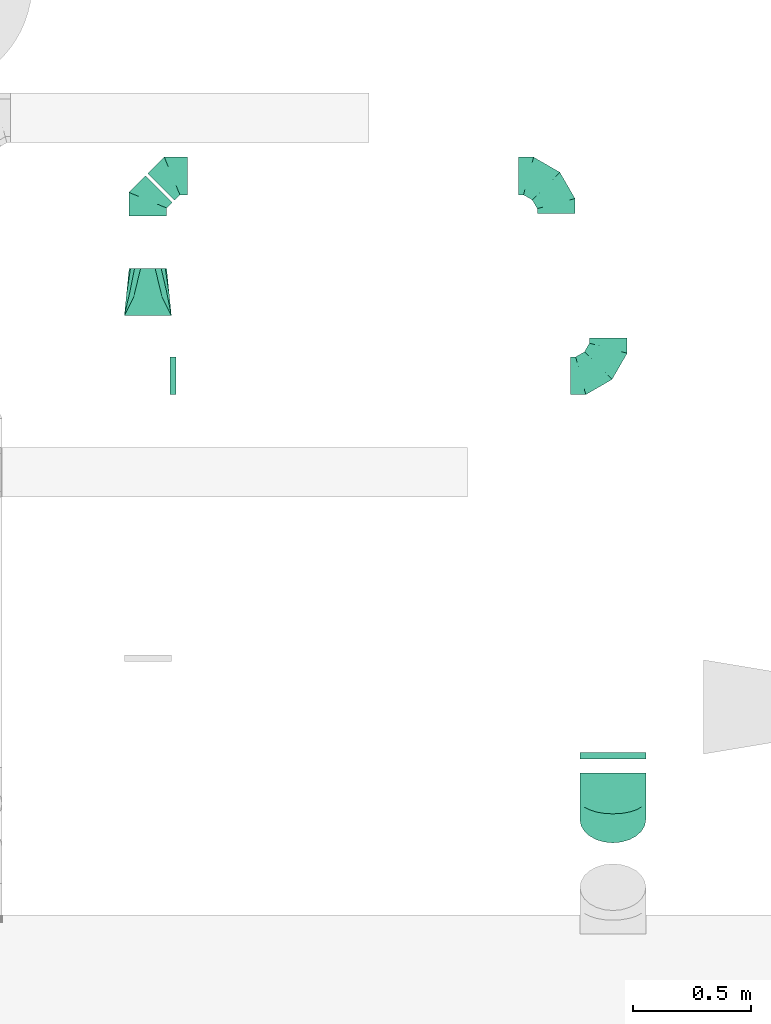
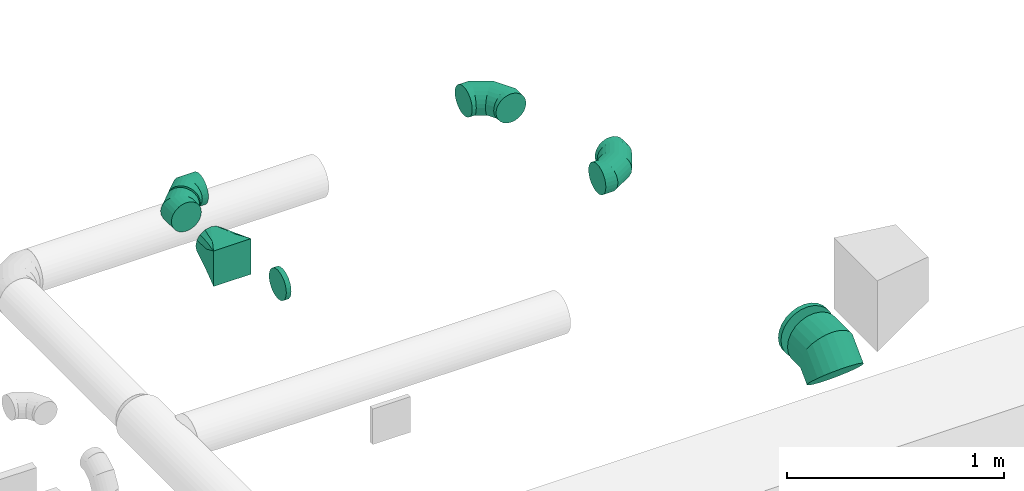
# One storey, part 44 of 62: 8 flow fittings.
"""IFC2X3 building model written with IfcOpenShell, lengths in millimetres."""

from ifc_helpers import new_model, entity, si_unit, converted_unit, derived_unit, direction, frame, origin, place, context, subcontext, project, spatial, faceted_brep, source, transform, mapped, material, type_object, type_shapes, element, save


model = new_model("IFC2X3")

# Units and contexts
model_context = context("Model", 3, precision=0.01, world=origin(), true_north=direction((6.12303176911189e-17, 1.0)))
body_context = subcontext(model_context, "Body", "Model", "MODEL_VIEW")
ifc_project = project(units=[si_unit("LENGTHUNIT", "METRE", prefix="MILLI"), si_unit("AREAUNIT", "SQUARE_METRE"), si_unit("VOLUMEUNIT", "CUBIC_METRE"), converted_unit("PLANEANGLEUNIT", "DEGREE", entity("IfcRatioMeasure", 0.0174532925199433), si_unit("PLANEANGLEUNIT", "RADIAN"), dimensions=[0, 0, 0, 0, 0, 0, 0]), si_unit("MASSUNIT", "GRAM", prefix="KILO"), derived_unit("MASSDENSITYUNIT", [(si_unit("MASSUNIT", "GRAM", prefix="KILO"), 1), (si_unit("LENGTHUNIT", "METRE"), -3)]), derived_unit("MOMENTOFINERTIAUNIT", [(si_unit("LENGTHUNIT", "METRE"), 4)]), si_unit("TIMEUNIT", "SECOND"), si_unit("FREQUENCYUNIT", "HERTZ"), si_unit("THERMODYNAMICTEMPERATUREUNIT", "DEGREE_CELSIUS"), derived_unit("THERMALTRANSMITTANCEUNIT", [(si_unit("MASSUNIT", "GRAM", prefix="KILO"), 1), (si_unit("THERMODYNAMICTEMPERATUREUNIT", "KELVIN"), -1), (si_unit("TIMEUNIT", "SECOND"), -3)]), derived_unit("VOLUMETRICFLOWRATEUNIT", [(si_unit("LENGTHUNIT", "METRE"), 3), (si_unit("TIMEUNIT", "SECOND"), -1)]), derived_unit("MASSFLOWRATEUNIT", [(si_unit("MASSUNIT", "GRAM", prefix="KILO"), 1), (si_unit("TIMEUNIT", "SECOND"), -1)]), derived_unit("ROTATIONALFREQUENCYUNIT", [(si_unit("TIMEUNIT", "SECOND"), -1)]), si_unit("ELECTRICCURRENTUNIT", "AMPERE"), si_unit("ELECTRICVOLTAGEUNIT", "VOLT"), si_unit("POWERUNIT", "WATT"), si_unit("FORCEUNIT", "NEWTON", prefix="KILO"), si_unit("ILLUMINANCEUNIT", "LUX"), si_unit("LUMINOUSFLUXUNIT", "LUMEN"), si_unit("LUMINOUSINTENSITYUNIT", "CANDELA"), derived_unit("USERDEFINED", [(si_unit("MASSUNIT", "GRAM", prefix="KILO"), -1), (si_unit("LENGTHUNIT", "METRE"), -2), (si_unit("TIMEUNIT", "SECOND"), 3), (si_unit("LUMINOUSFLUXUNIT", "LUMEN"), 1)]), derived_unit("LINEARVELOCITYUNIT", [(si_unit("LENGTHUNIT", "METRE"), 1), (si_unit("TIMEUNIT", "SECOND"), -1)]), si_unit("PRESSUREUNIT", "PASCAL"), derived_unit("USERDEFINED", [(si_unit("LENGTHUNIT", "METRE"), -2), (si_unit("MASSUNIT", "GRAM", prefix="KILO"), 1), (si_unit("TIMEUNIT", "SECOND"), -2)]), derived_unit("LINEARFORCEUNIT", [(si_unit("MASSUNIT", "GRAM", prefix="KILO"), 1), (si_unit("LENGTHUNIT", "METRE"), 1), (si_unit("TIMEUNIT", "SECOND"), -2), (si_unit("LENGTHUNIT", "METRE"), -1)]), derived_unit("PLANARFORCEUNIT", [(si_unit("MASSUNIT", "GRAM", prefix="KILO"), 1), (si_unit("LENGTHUNIT", "METRE"), 1), (si_unit("TIMEUNIT", "SECOND"), -2), (si_unit("LENGTHUNIT", "METRE"), -2)])], contexts=[model_context])

# Site, building, storey
site_placement = place(None, origin())
site = spatial("IfcSite", under=ifc_project, at=site_placement, CompositionType="ELEMENT")
building_placement = place(site_placement, origin())
building = spatial("IfcBuilding", under=site, at=building_placement, CompositionType="ELEMENT")
storey_placement = place(building_placement, frame((0.0, 0.0, 24000.0)))
storey = spatial("IfcBuildingStorey", under=building, at=storey_placement, CompositionType="ELEMENT", Elevation=24000.0)

# Flow fittings
ifc_material = material()
duct_fitting_type_1 = type_object("IfcDuctFittingType", PredefinedType="NOTDEFINED", material=ifc_material)
shared_shape_1 = source(origin(), body_context, "Body", "Brep", [
    faceted_brep([(-160.0, 0.0, -80.0), (-160.0, -20.71, -77.27), (-160.0, -40.0, -69.28), (-160.0, -56.57, -56.57), (-160.0, -69.28, -40.0), (-160.0, -77.27, -20.71), (-160.0, -80.0, 0.0), (-160.0, -77.27, 20.71), (-160.0, -69.28, 40.0), (-160.0, -56.57, 56.57), (-160.0, -40.0, 69.28), (-160.0, -20.71, 77.27), (-160.0, 0.0, 80.0), (-160.0, 20.71, 77.27), (-160.0, 40.0, 69.28), (-160.0, 56.57, 56.57), (-160.0, 69.28, 40.0), (-160.0, 77.27, 20.71), (-160.0, 80.0, 0.0), (-160.0, 77.27, -20.71), (-160.0, 69.28, -40.0), (-160.0, 56.57, -56.57), (-160.0, 40.0, -69.28), (-160.0, 20.71, -77.27), (-122.68, 20.71, 77.27), (-127.85, 40.0, 69.28), (-117.13, 0.0, 80.0), (-132.29, 56.57, 56.57), (-137.83, 77.27, 20.71), (-138.56, 80.0, 0.0), (-135.69, 69.28, 40.0), (-135.69, 69.28, -40.0), (-132.29, 56.57, -56.57), (-137.83, 77.27, -20.71), (-122.68, 20.71, -77.27), (-117.13, 0.0, -80.0), (-127.85, 40.0, -69.28), (-111.58, -20.71, -77.27), (-106.41, -40.0, -69.28), (-101.97, -56.57, -56.57), (-98.56, -69.28, -40.0), (-96.42, -77.27, -20.71), (-95.69, -80.0, 0.0), (-96.42, -77.27, 20.71), (-98.56, -69.28, 40.0), (-101.97, -56.57, 56.57), (-106.41, -40.0, 69.28), (-111.58, -20.71, 77.27), (-58.03, 58.03, 77.27), (-72.15, 72.15, 69.28), (-42.87, 42.87, 80.0), (-84.28, 84.28, 56.57), (-93.59, 93.59, 40.0), (-99.44, 99.44, 20.71), (-101.44, 101.44, 0.0), (-99.44, 99.44, -20.71), (-93.59, 93.59, -40.0), (-84.28, 84.28, -56.57), (-58.03, 58.03, -77.27), (-42.87, 42.87, -80.0), (-72.15, 72.15, -69.28), (-27.71, 27.71, -77.27), (-13.59, 13.59, -69.28), (-1.46, 1.46, -56.57), (7.85, -7.85, -40.0), (13.7, -13.7, -20.71), (15.69, -15.69, 0.0), (13.7, -13.7, 20.71), (7.85, -7.85, 40.0), (-1.46, 1.46, 56.57), (-13.59, 13.59, 69.28), (-27.71, 27.71, 77.27), (-20.71, 122.68, 77.27), (-40.0, 127.85, 69.28), (0.0, 117.13, 80.0), (-56.57, 132.29, 56.57), (-69.28, 135.69, 40.0), (-77.27, 137.83, 20.71), (-80.0, 138.56, 0.0), (-77.27, 137.83, -20.71), (-69.28, 135.69, -40.0), (-56.57, 132.29, -56.57), (-20.71, 122.68, -77.27), (0.0, 117.13, -80.0), (-40.0, 127.85, -69.28), (20.71, 111.58, -77.27), (40.0, 106.41, -69.28), (56.57, 101.97, -56.57), (69.28, 98.56, -40.0), (77.27, 96.42, -20.71), (80.0, 95.69, 0.0), (77.27, 96.42, 20.71), (69.28, 98.56, 40.0), (56.57, 101.97, 56.57), (40.0, 106.41, 69.28), (20.71, 111.58, 77.27), (-20.71, 160.0, -77.27), (-40.0, 160.0, -69.28), (-56.57, 160.0, -56.57), (-69.28, 160.0, -40.0), (-77.27, 160.0, -20.71), (-80.0, 160.0, 0.0), (-77.27, 160.0, 20.71), (-69.28, 160.0, 40.0), (-56.57, 160.0, 56.57), (-40.0, 160.0, 69.28), (-20.71, 160.0, 77.27), (0.0, 160.0, 80.0), (20.71, 160.0, 77.27), (40.0, 160.0, 69.28), (56.57, 160.0, 56.57), (69.28, 160.0, 40.0), (77.27, 160.0, 20.71), (80.0, 160.0, 0.0), (77.27, 160.0, -20.71), (69.28, 160.0, -40.0), (56.57, 160.0, -56.57), (40.0, 160.0, -69.28), (20.71, 160.0, -77.27), (0.0, 160.0, -80.0)], [[[0, 1, 2, 3, 4, 5, 6, 7, 8, 9, 10, 11, 12, 13, 14, 15, 16, 17, 18, 19, 20, 21, 22, 23]], [[24, 25, 14, 13]], [[26, 24, 13, 12]], [[14, 25, 27, 15]], [[28, 29, 18, 17]], [[30, 28, 17, 16]], [[15, 27, 30, 16]], [[20, 31, 32, 21]], [[33, 31, 20, 19]], [[18, 29, 33, 19]], [[34, 35, 0, 23]], [[36, 34, 23, 22]], [[32, 36, 22, 21]], [[1, 0, 35, 37]], [[2, 1, 37, 38]], [[3, 2, 38, 39]], [[5, 4, 40, 41]], [[6, 5, 41, 42]], [[39, 40, 4, 3]], [[6, 42, 43, 7]], [[7, 43, 44, 8]], [[8, 44, 45, 9]], [[9, 45, 46, 10]], [[10, 46, 47, 11]], [[26, 12, 11, 47]], [[48, 49, 25, 24]], [[50, 48, 24, 26]], [[27, 25, 49, 51]], [[52, 53, 28, 30]], [[51, 52, 30, 27]], [[29, 28, 53, 54]], [[55, 56, 31, 33]], [[54, 55, 33, 29]], [[32, 31, 56, 57]], [[58, 59, 35, 34]], [[60, 58, 34, 36]], [[57, 60, 36, 32]], [[37, 35, 59, 61]], [[38, 37, 61, 62]], [[39, 38, 62, 63]], [[41, 40, 64, 65]], [[42, 41, 65, 66]], [[63, 64, 40, 39]], [[43, 42, 66, 67]], [[44, 43, 67, 68]], [[68, 69, 45, 44]], [[46, 45, 69, 70]], [[47, 46, 70, 71]], [[26, 47, 71, 50]], [[72, 73, 49, 48]], [[74, 72, 48, 50]], [[51, 49, 73, 75]], [[76, 77, 53, 52]], [[75, 76, 52, 51]], [[54, 53, 77, 78]], [[79, 80, 56, 55]], [[78, 79, 55, 54]], [[57, 56, 80, 81]], [[82, 83, 59, 58]], [[84, 82, 58, 60]], [[81, 84, 60, 57]], [[61, 59, 83, 85]], [[62, 61, 85, 86]], [[63, 62, 86, 87]], [[65, 64, 88, 89]], [[66, 65, 89, 90]], [[87, 88, 64, 63]], [[67, 66, 90, 91]], [[68, 67, 91, 92]], [[92, 93, 69, 68]], [[70, 69, 93, 94]], [[71, 70, 94, 95]], [[50, 71, 95, 74]], [[96, 97, 98, 99, 100, 101, 102, 103, 104, 105, 106, 107, 108, 109, 110, 111, 112, 113, 114, 115, 116, 117, 118, 119]], [[72, 74, 107, 106]], [[73, 72, 106, 105]], [[75, 73, 105, 104]], [[77, 76, 103, 102]], [[78, 77, 102, 101]], [[75, 104, 103, 76]], [[78, 101, 100, 79]], [[79, 100, 99, 80]], [[80, 99, 98, 81]], [[84, 97, 96, 82]], [[82, 96, 119, 83]], [[84, 81, 98, 97]], [[118, 117, 86, 85]], [[119, 118, 85, 83]], [[116, 87, 86, 117]], [[88, 115, 114, 89]], [[89, 114, 113, 90]], [[115, 88, 87, 116]], [[112, 111, 92, 91]], [[113, 112, 91, 90]], [[111, 110, 93, 92]], [[95, 94, 109, 108]], [[74, 95, 108, 107]], [[110, 109, 94, 93]]]),
])
type_shapes(duct_fitting_type_1, [shared_shape_1])
flow_fitting_1_placement = place(storey_placement, frame((56810.22, 12336.18, 3550.0), z_axis=(0.0, 0.0, 1.0), x_axis=(0.0, 1.0, 0.0)))
element("IfcFlowFitting", 1, at=flow_fitting_1_placement, inside=storey, type_object=duct_fitting_type_1, material=ifc_material, context=body_context, shape_type="MappedRepresentation", body=[
    mapped(shared_shape_1, transform((0.0, 0.0, 0.0), scale=1.0)),
])
flow_fitting_2_placement = place(storey_placement, frame((57031.65, 11488.11, 3550.0)))
element("IfcFlowFitting", 2, at=flow_fitting_2_placement, inside=storey, type_object=duct_fitting_type_1, material=ifc_material, context=body_context, shape_type="MappedRepresentation", body=[
    mapped(shared_shape_1, transform((0.0, 0.0, 0.0), scale=1.0)),
])
duct_fitting_type_2 = type_object("IfcDuctFittingType", PredefinedType="NOTDEFINED", material=ifc_material)
shared_shape_2 = source(origin(), body_context, "Body", "Brep", [
    faceted_brep([(20.0, 0.0, -80.0), (20.0, 20.71, -77.27), (20.0, 40.0, -69.28), (20.0, 56.57, -56.57), (20.0, 69.28, -40.0), (20.0, 77.27, -20.71), (20.0, 80.0, 0.0), (20.0, 77.27, 20.71), (20.0, 69.28, 40.0), (20.0, 56.57, 56.57), (20.0, 40.0, 69.28), (20.0, 20.71, 77.27), (20.0, 0.0, 80.0), (20.0, -20.71, 77.27), (20.0, -40.0, 69.28), (20.0, -56.57, 56.57), (20.0, -69.28, 40.0), (20.0, -77.27, 20.71), (20.0, -80.0, 0.0), (20.0, -77.27, -20.71), (20.0, -69.28, -40.0), (20.0, -56.57, -56.57), (20.0, -40.0, -69.28), (20.0, -20.71, -77.27), (0.0, 0.0, 80.0), (-6.1, 0.0, 80.0), (-6.1, -20.71, 77.27), (0.0, -20.71, 77.27), (-6.1, -40.0, 69.28), (0.0, -40.0, 69.28), (0.0, -56.57, 56.57), (-6.1, -56.57, 56.57), (0.0, -69.28, 40.0), (-6.1, -69.28, 40.0), (-6.1, -77.27, 20.71), (0.0, -77.27, 20.71), (-6.1, -80.0, 0.0), (0.0, -80.0, 0.0), (-6.1, -77.27, -20.71), (0.0, -77.27, -20.71), (-6.1, -69.28, -40.0), (0.0, -69.28, -40.0), (0.0, -56.57, -56.57), (-6.1, -56.57, -56.57), (0.0, -40.0, -69.28), (-6.1, -40.0, -69.28), (-6.1, -20.71, -77.27), (0.0, -20.71, -77.27), (-6.1, 0.0, -80.0), (0.0, 0.0, -80.0), (-6.1, 20.71, -77.27), (0.0, 20.71, -77.27), (-6.1, 40.0, -69.28), (0.0, 40.0, -69.28), (0.0, 56.57, -56.57), (-6.1, 56.57, -56.57), (0.0, 69.28, -40.0), (-6.1, 69.28, -40.0), (-6.1, 77.27, -20.71), (0.0, 77.27, -20.71), (-6.1, 80.0, 0.0), (0.0, 80.0, 0.0), (-6.1, 77.27, 20.71), (0.0, 77.27, 20.71), (-6.1, 69.28, 40.0), (0.0, 69.28, 40.0), (0.0, 56.57, 56.57), (-6.1, 56.57, 56.57), (0.0, 40.0, 69.28), (-6.1, 40.0, 69.28), (-6.1, 20.71, 77.27), (0.0, 20.71, 77.27)], [[[0, 1, 2, 3, 4, 5, 6, 7, 8, 9, 10, 11, 12, 13, 14, 15, 16, 17, 18, 19, 20, 21, 22, 23]], [[13, 12, 24, 25, 26, 27]], [[14, 13, 27, 26, 28, 29]], [[30, 15, 14, 29, 28, 31]], [[17, 16, 32, 33, 34, 35]], [[18, 17, 35, 34, 36, 37]], [[32, 16, 15, 30, 31, 33]], [[19, 18, 37, 36, 38, 39]], [[20, 19, 39, 38, 40, 41]], [[42, 21, 20, 41, 40, 43]], [[23, 22, 44, 45, 46, 47]], [[0, 23, 47, 46, 48, 49]], [[44, 22, 21, 42, 43, 45]], [[1, 0, 49, 48, 50, 51]], [[2, 1, 51, 50, 52, 53]], [[54, 3, 2, 53, 52, 55]], [[5, 4, 56, 57, 58, 59]], [[6, 5, 59, 58, 60, 61]], [[56, 4, 3, 54, 55, 57]], [[7, 6, 61, 60, 62, 63]], [[8, 7, 63, 62, 64, 65]], [[66, 9, 8, 65, 64, 67]], [[11, 10, 68, 69, 70, 71]], [[12, 11, 71, 70, 25, 24]], [[68, 10, 9, 66, 67, 69]], [[46, 45, 43, 40, 38, 36, 34, 33, 31, 28, 26, 25, 70, 69, 67, 64, 62, 60, 58, 57, 55, 52, 50, 48]]]),
])
type_shapes(duct_fitting_type_2, [shared_shape_2])
flow_fitting_3_placement = place(storey_placement, frame((55177.37, 11488.11, 3550.0), z_axis=(0.0, 0.0, -1.0), x_axis=(1.0, 0.0, 0.0)))
element("IfcFlowFitting", 3, at=flow_fitting_3_placement, inside=storey, type_object=duct_fitting_type_2, material=ifc_material, context=body_context, shape_type="MappedRepresentation", body=[
    mapped(shared_shape_2, transform((0.0, 0.0, 0.0), scale=1.0)),
])
duct_fitting_type_3 = type_object("IfcDuctFittingType", PredefinedType="NOTDEFINED", material=ifc_material)
shared_shape_3 = source(origin(), body_context, "Body", "Brep", [
    faceted_brep([(-66.27, 0.0, -80.0), (-66.27, -20.71, -77.27), (-66.27, -40.0, -69.28), (-66.27, -56.57, -56.57), (-66.27, -69.28, -40.0), (-66.27, -77.27, -20.71), (-66.27, -80.0, 0.0), (-66.27, -77.27, 20.71), (-66.27, -69.28, 40.0), (-66.27, -56.57, 56.57), (-66.27, -40.0, 69.28), (-66.27, -20.71, 77.27), (-66.27, 0.0, 80.0), (-66.27, 20.71, 77.27), (-66.27, 40.0, 69.28), (-66.27, 56.57, 56.57), (-66.27, 69.28, 40.0), (-66.27, 77.27, 20.71), (-66.27, 80.0, 0.0), (-66.27, 77.27, -20.71), (-66.27, 69.28, -40.0), (-66.27, 56.57, -56.57), (-66.27, 40.0, -69.28), (-66.27, 20.71, -77.27), (-8.58, 20.71, 77.27), (-16.57, 40.0, 69.28), (0.0, 0.0, 80.0), (-23.43, 56.57, 56.57), (-28.7, 69.28, 40.0), (-32.01, 77.27, 20.71), (-33.14, 80.0, 0.0), (-32.01, 77.27, -20.71), (-28.7, 69.28, -40.0), (-23.43, 56.57, -56.57), (-8.58, 20.71, -77.27), (0.0, 0.0, -80.0), (-16.57, 40.0, -69.28), (8.58, -20.71, -77.27), (16.57, -40.0, -69.28), (23.43, -56.57, -56.57), (28.7, -69.28, -40.0), (32.01, -77.27, -20.71), (33.14, -80.0, 0.0), (32.01, -77.27, 20.71), (28.7, -69.28, 40.0), (23.43, -56.57, 56.57), (16.57, -40.0, 69.28), (8.58, -20.71, 77.27), (46.86, 46.86, 80.0), (32.22, 61.5, 77.27), (18.58, 75.15, 69.28), (6.86, 86.86, 56.57), (-2.13, 95.85, 40.0), (-7.78, 101.5, 20.71), (-9.71, 103.43, 0.0), (-7.78, 101.5, -20.71), (-2.13, 95.85, -40.0), (6.86, 86.86, -56.57), (18.58, 75.15, -69.28), (32.22, 61.5, -77.27), (46.86, 46.86, -80.0), (61.5, 32.22, -77.27), (75.15, 18.58, -69.28), (86.86, 6.86, -56.57), (95.85, -2.13, -40.0), (101.5, -7.78, -20.71), (103.43, -9.71, 0.0), (101.5, -7.78, 20.71), (95.85, -2.13, 40.0), (86.86, 6.86, 56.57), (75.15, 18.58, 69.28), (61.5, 32.22, 77.27)], [[[0, 1, 2, 3, 4, 5, 6, 7, 8, 9, 10, 11, 12, 13, 14, 15, 16, 17, 18, 19, 20, 21, 22, 23]], [[24, 25, 14, 13]], [[26, 24, 13, 12]], [[14, 25, 27, 15]], [[28, 29, 17, 16]], [[28, 16, 15, 27]], [[30, 18, 17, 29]], [[31, 32, 20, 19]], [[30, 31, 19, 18]], [[32, 33, 21, 20]], [[34, 35, 0, 23]], [[36, 34, 23, 22]], [[33, 36, 22, 21]], [[1, 0, 35, 37]], [[2, 1, 37, 38]], [[38, 39, 3, 2]], [[5, 4, 40, 41]], [[6, 5, 41, 42]], [[39, 40, 4, 3]], [[6, 42, 43, 7]], [[7, 43, 44, 8]], [[8, 44, 45, 9]], [[9, 45, 46, 10]], [[10, 46, 47, 11]], [[26, 12, 11, 47]], [[24, 26, 48, 49]], [[25, 24, 49, 50]], [[27, 25, 50, 51]], [[29, 28, 52, 53]], [[30, 29, 53, 54]], [[51, 52, 28, 27]], [[30, 54, 55, 31]], [[31, 55, 56, 32]], [[57, 33, 32, 56]], [[36, 58, 59, 34]], [[34, 59, 60, 35]], [[58, 36, 33, 57]], [[35, 60, 61, 37]], [[37, 61, 62, 38]], [[63, 39, 38, 62]], [[40, 64, 65, 41]], [[41, 65, 66, 42]], [[64, 40, 39, 63]], [[43, 42, 66, 67]], [[44, 43, 67, 68]], [[68, 69, 45, 44]], [[47, 46, 70, 71]], [[26, 47, 71, 48]], [[69, 70, 46, 45]], [[59, 58, 57, 56, 55, 54, 53, 52, 51, 50, 49, 48, 71, 70, 69, 68, 67, 66, 65, 64, 63, 62, 61, 60]]]),
])
type_shapes(duct_fitting_type_3, [shared_shape_3])
for number, where, z_axis, x_axis in (
    (4, (55077.37, 12233.33, 3550.0), (0.0, 0.0, 1.0), (-0.70710678118655, -0.707106781186545, 0.0)),
    (5, (55180.22, 12336.18, 3550.0), (0.0, 0.0, 1.0), (-1.0, 0.0, 0.0)),
):
    element("IfcFlowFitting", number, at=place(storey_placement, frame(where, z_axis=z_axis, x_axis=x_axis)), inside=storey, type_object=duct_fitting_type_3, material=ifc_material, context=body_context, shape_type="MappedRepresentation", body=[
        mapped(shared_shape_3, transform((0.0, 0.0, 0.0), scale=1.0)),
    ])
duct_fitting_type_4 = type_object("IfcDuctFittingType", PredefinedType="NOTDEFINED", material=ifc_material)
shared_shape_4 = source(origin(), body_context, "Body", "Brep", [
    faceted_brep([(200.0, 30.61, 73.91), (200.0, 22.87, 75.45), (200.0, 15.12, 76.99), (200.0, 11.34, 77.74), (200.0, 7.56, 78.5), (200.0, 0.0, 80.0), (200.0, -7.56, 78.5), (200.0, -15.12, 76.99), (200.0, -18.99, 76.22), (200.0, -22.87, 75.45), (200.0, -30.61, 73.91), (200.0, -37.1, 69.57), (200.0, -43.59, 65.24), (200.0, -50.08, 60.9), (200.0, -56.57, 56.57), (200.0, -60.9, 50.08), (200.0, -65.24, 43.59), (200.0, -69.57, 37.1), (200.0, -73.91, 30.61), (200.0, -75.45, 22.87), (200.0, -76.99, 15.12), (200.0, -77.74, 11.34), (200.0, -78.5, 7.56), (200.0, -80.0, 0.0), (200.0, -78.5, -7.56), (200.0, -76.99, -15.12), (200.0, -76.22, -18.99), (200.0, -75.45, -22.87), (200.0, -73.91, -30.61), (200.0, -69.57, -37.1), (200.0, -65.24, -43.59), (200.0, -60.9, -50.08), (200.0, -56.57, -56.57), (200.0, -50.08, -60.9), (200.0, -43.59, -65.24), (200.0, -37.1, -69.57), (200.0, -30.61, -73.91), (200.0, -22.87, -75.45), (200.0, -15.12, -76.99), (200.0, -11.34, -77.74), (200.0, -7.56, -78.5), (200.0, 0.0, -80.0), (200.0, 7.56, -78.5), (200.0, 15.12, -76.99), (200.0, 18.99, -76.22), (200.0, 22.87, -75.45), (200.0, 30.61, -73.91), (200.0, 37.1, -69.57), (200.0, 43.59, -65.24), (200.0, 50.08, -60.9), (200.0, 56.57, -56.57), (200.0, 60.9, -50.08), (200.0, 65.24, -43.59), (200.0, 69.57, -37.1), (200.0, 73.91, -30.61), (200.0, 75.45, -22.87), (200.0, 76.99, -15.12), (200.0, 77.74, -11.34), (200.0, 78.5, -7.56), (200.0, 80.0, 0.0), (200.0, 78.5, 7.56), (200.0, 76.99, 15.12), (200.0, 76.22, 18.99), (200.0, 75.45, 22.87), (200.0, 73.91, 30.61), (200.0, 69.57, 37.1), (200.0, 65.24, 43.59), (200.0, 60.9, 50.08), (200.0, 56.57, 56.57), (200.0, 50.08, 60.9), (200.0, 43.59, 65.24), (200.0, 37.1, 69.57), (0.0, -100.0, 100.0), (0.0, 100.0, 100.0), (0.0, 100.0, -100.0), (0.0, -100.0, -100.0), (52.06, -73.97, 94.79), (78.09, -60.96, 92.19), (176.03, -11.99, 82.4), (152.06, -23.97, 84.79), (128.09, -35.96, 87.19), (104.11, -47.94, 89.59), (100.0, -79.94, 76.52), (78.09, -92.19, 60.96), (104.11, -89.59, 47.94), (128.09, -87.19, 35.96), (152.06, -84.79, 23.97), (164.04, -83.6, 17.98), (176.03, -82.4, 11.99), (26.03, -97.4, 86.99), (52.06, -94.79, 73.97), (26.03, -86.99, 97.4), (26.03, -97.4, -86.99), (52.06, -94.79, -73.97), (78.09, -92.19, -60.96), (104.11, -89.59, -47.94), (128.09, -87.19, -35.96), (152.06, -84.79, -23.97), (176.03, -82.4, -11.99), (100.0, -76.52, -79.94), (78.09, -60.96, -92.19), (104.11, -47.94, -89.59), (128.09, -35.96, -87.19), (152.06, -23.97, -84.79), (164.04, -17.98, -83.6), (176.03, -11.99, -82.4), (26.03, -86.99, -97.4), (52.06, -73.97, -94.79), (26.03, 86.99, -97.4), (52.06, 73.97, -94.79), (78.09, 60.96, -92.19), (104.11, 47.94, -89.59), (128.09, 35.96, -87.19), (152.06, 23.97, -84.79), (176.03, 11.99, -82.4), (100.0, 79.94, -76.52), (78.09, 92.19, -60.96), (104.11, 89.59, -47.94), (128.09, 87.19, -35.96), (152.06, 84.79, -23.97), (164.04, 83.6, -17.98), (176.03, 82.4, -11.99), (26.03, 97.4, -86.99), (52.06, 94.79, -73.97), (26.03, 97.4, 86.99), (52.06, 94.79, 73.97), (78.09, 92.19, 60.96), (104.11, 89.59, 47.94), (128.09, 87.19, 35.96), (152.06, 84.79, 23.97), (176.03, 82.4, 11.99), (100.0, 76.52, 79.94), (78.09, 60.96, 92.19), (104.11, 47.94, 89.59), (128.09, 35.96, 87.19), (152.06, 23.97, 84.79), (164.04, 17.98, 83.6), (176.03, 11.99, 82.4), (26.03, 86.99, 97.4), (52.06, 73.97, 94.79)], [[[0, 1, 2, 3, 4, 5, 6, 7, 8, 9, 10, 11, 12, 13, 14, 15, 16, 17, 18, 19, 20, 21, 22, 23, 24, 25, 26, 27, 28, 29, 30, 31, 32, 33, 34, 35, 36, 37, 38, 39, 40, 41, 42, 43, 44, 45, 46, 47, 48, 49, 50, 51, 52, 53, 54, 55, 56, 57, 58, 59, 60, 61, 62, 63, 64, 65, 66, 67, 68, 69, 70, 71]], [[72, 73, 74, 75]], [[76, 12, 77]], [[12, 11, 10, 77]], [[78, 79, 80, 81, 77, 10, 9, 8, 7, 6, 5]], [[13, 82, 14]], [[20, 19, 18, 83, 84, 85, 86, 87, 88, 23, 22, 21]], [[82, 72, 89]], [[82, 15, 14]], [[83, 16, 90]], [[91, 72, 82]], [[18, 17, 16, 83]], [[90, 16, 15]], [[15, 82, 89]], [[90, 15, 89]], [[76, 13, 12]], [[13, 76, 91]], [[82, 13, 91]], [[88, 87, 86, 85, 84, 83, 90, 89, 72, 75, 92, 93, 94, 95, 96, 97, 98, 23]], [[93, 30, 94]], [[30, 29, 28, 94]], [[98, 97, 96, 95, 94, 28, 27, 26, 25, 24, 23]], [[31, 99, 32]], [[38, 37, 36, 100, 101, 102, 103, 104, 105, 41, 40, 39]], [[99, 75, 106]], [[99, 33, 32]], [[100, 34, 107]], [[92, 75, 99]], [[36, 35, 34, 100]], [[107, 34, 33]], [[33, 99, 106]], [[107, 33, 106]], [[93, 31, 30]], [[31, 93, 92]], [[99, 31, 92]], [[105, 104, 103, 102, 101, 100, 107, 106, 75, 74, 108, 109, 110, 111, 112, 113, 114, 41]], [[109, 48, 110]], [[48, 47, 46, 110]], [[114, 113, 112, 111, 110, 46, 45, 44, 43, 42, 41]], [[49, 115, 50]], [[56, 55, 54, 116, 117, 118, 119, 120, 121, 59, 58, 57]], [[115, 74, 122]], [[115, 51, 50]], [[116, 52, 123]], [[108, 74, 115]], [[54, 53, 52, 116]], [[123, 52, 51]], [[51, 115, 122]], [[123, 51, 122]], [[109, 49, 48]], [[49, 109, 108]], [[115, 49, 108]], [[74, 73, 124, 125, 126, 127, 128, 129, 130, 59, 121, 120, 119, 118, 117, 116, 123, 122]], [[125, 66, 126]], [[66, 65, 64, 126]], [[130, 129, 128, 127, 126, 64, 63, 62, 61, 60, 59]], [[67, 131, 68]], [[2, 1, 0, 132, 133, 134, 135, 136, 137, 5, 4, 3]], [[131, 73, 138]], [[131, 69, 68]], [[132, 70, 139]], [[124, 73, 131]], [[0, 71, 70, 132]], [[139, 70, 69]], [[69, 131, 138]], [[139, 69, 138]], [[125, 67, 66]], [[67, 125, 124]], [[131, 67, 124]], [[73, 72, 91, 76, 77, 81, 80, 79, 78, 5, 137, 136, 135, 134, 133, 132, 139, 138]]]),
])
type_shapes(duct_fitting_type_4, [shared_shape_4])
flow_fitting_4_placement = place(storey_placement, frame((55077.37, 11743.33, 3550.0), z_axis=(0.0, 0.0, 1.0), x_axis=(0.0, 1.0, 0.0)))
element("IfcFlowFitting", 6, at=flow_fitting_4_placement, inside=storey, type_object=duct_fitting_type_4, material=ifc_material, context=body_context, shape_type="MappedRepresentation", body=[
    mapped(shared_shape_4, transform((0.0, 0.0, 0.0), scale=1.0)),
])
duct_fitting_type_5 = type_object("IfcDuctFittingType", PredefinedType="NOTDEFINED", material=ifc_material)
shared_shape_5 = source(origin(), body_context, "Body", "Brep", [
    faceted_brep([(20.0, 36.23, -135.23), (20.0, 70.0, -121.24), (20.0, 98.99, -98.99), (20.0, 121.24, -70.0), (20.0, 135.23, -36.23), (20.0, 140.0, 0.0), (20.0, 135.23, 36.23), (20.0, 121.24, 70.0), (20.0, 98.99, 98.99), (20.0, 70.0, 121.24), (20.0, 36.23, 135.23), (20.0, 0.0, 140.0), (20.0, -36.23, 135.23), (20.0, -70.0, 121.24), (20.0, -98.99, 98.99), (20.0, -121.24, 70.0), (20.0, -135.23, 36.23), (20.0, -140.0, 0.0), (20.0, -135.23, -36.23), (20.0, -121.24, -70.0), (20.0, -98.99, -98.99), (20.0, -70.0, -121.24), (20.0, -36.23, -135.23), (20.0, 0.0, -140.0), (0.0, 0.0, 140.0), (0.0, 36.23, 135.23), (-6.1, 36.23, 135.23), (-6.1, 0.0, 140.0), (0.0, 70.0, 121.24), (-6.1, 70.0, 121.24), (0.0, 98.99, 98.99), (-6.1, 98.99, 98.99), (0.0, 121.24, 70.0), (0.0, 135.23, 36.23), (-6.1, 135.23, 36.23), (-6.1, 121.24, 70.0), (0.0, 140.0, 0.0), (-6.1, 140.0, 0.0), (0.0, 135.23, -36.23), (-6.1, 135.23, -36.23), (0.0, 121.24, -70.0), (-6.1, 121.24, -70.0), (0.0, 98.99, -98.99), (-6.1, 98.99, -98.99), (0.0, 70.0, -121.24), (0.0, 36.23, -135.23), (-6.1, 36.23, -135.23), (-6.1, 70.0, -121.24), (0.0, 0.0, -140.0), (-6.1, 0.0, -140.0), (0.0, -36.23, -135.23), (-6.1, -36.23, -135.23), (0.0, -70.0, -121.24), (-6.1, -70.0, -121.24), (0.0, -98.99, -98.99), (-6.1, -98.99, -98.99), (0.0, -121.24, -70.0), (0.0, -135.23, -36.23), (-6.1, -135.23, -36.23), (-6.1, -121.24, -70.0), (0.0, -140.0, 0.0), (-6.1, -140.0, 0.0), (0.0, -135.23, 36.23), (-6.1, -135.23, 36.23), (0.0, -121.24, 70.0), (-6.1, -121.24, 70.0), (0.0, -98.99, 98.99), (-6.1, -98.99, 98.99), (0.0, -70.0, 121.24), (0.0, -36.23, 135.23), (-6.1, -36.23, 135.23), (-6.1, -70.0, 121.24)], [[[0, 1, 2, 3, 4, 5, 6, 7, 8, 9, 10, 11, 12, 13, 14, 15, 16, 17, 18, 19, 20, 21, 22, 23]], [[24, 11, 10, 25, 26, 27]], [[25, 10, 9, 28, 29, 26]], [[28, 9, 8, 30, 31, 29]], [[32, 7, 6, 33, 34, 35]], [[33, 6, 5, 36, 37, 34]], [[30, 8, 7, 32, 35, 31]], [[36, 5, 4, 38, 39, 37]], [[38, 4, 3, 40, 41, 39]], [[40, 3, 2, 42, 43, 41]], [[44, 1, 0, 45, 46, 47]], [[45, 0, 23, 48, 49, 46]], [[42, 2, 1, 44, 47, 43]], [[48, 23, 22, 50, 51, 49]], [[50, 22, 21, 52, 53, 51]], [[52, 21, 20, 54, 55, 53]], [[56, 19, 18, 57, 58, 59]], [[57, 18, 17, 60, 61, 58]], [[54, 20, 19, 56, 59, 55]], [[60, 17, 16, 62, 63, 61]], [[62, 16, 15, 64, 65, 63]], [[64, 15, 14, 66, 67, 65]], [[68, 13, 12, 69, 70, 71]], [[69, 12, 11, 24, 27, 70]], [[66, 14, 13, 68, 71, 67]], [[49, 51, 53, 55, 59, 58, 61, 63, 65, 67, 71, 70, 27, 26, 29, 31, 35, 34, 37, 39, 41, 43, 47, 46]]]),
])
type_shapes(duct_fitting_type_5, [shared_shape_5])
flow_fitting_5_placement = place(storey_placement, frame((57051.15, 9882.41, 3610.0), z_axis=(0.0, 0.0, -1.0), x_axis=(0.0, -1.0, 0.0)))
element("IfcFlowFitting", 7, at=flow_fitting_5_placement, inside=storey, type_object=duct_fitting_type_5, material=ifc_material, context=body_context, shape_type="MappedRepresentation", body=[
    mapped(shared_shape_5, transform((0.0, 0.0, 0.0), scale=1.0)),
])
duct_fitting_type_6 = type_object("IfcDuctFittingType", PredefinedType="NOTDEFINED", material=ifc_material)
shared_shape_6 = source(origin(), body_context, "Body", "Brep", [
    faceted_brep([(-115.98, 0.0, -140.0), (-115.98, -36.23, -135.23), (-115.98, -70.0, -121.24), (-115.98, -98.99, -98.99), (-115.98, -121.24, -70.0), (-115.98, -135.23, -36.23), (-115.98, -140.0, 0.0), (-115.98, -135.23, 36.23), (-115.98, -121.24, 70.0), (-115.98, -98.99, 98.99), (-115.98, -70.0, 121.24), (-115.98, -36.23, 135.23), (-115.98, 0.0, 140.0), (-115.98, 36.23, 135.23), (-115.98, 70.0, 121.24), (-115.98, 98.99, 98.99), (-115.98, 121.24, 70.0), (-115.98, 135.23, 36.23), (-115.98, 140.0, 0.0), (-115.98, 135.23, -36.23), (-115.98, 121.24, -70.0), (-115.98, 98.99, -98.99), (-115.98, 70.0, -121.24), (-115.98, 36.23, -135.23), (-15.01, 36.23, 135.23), (-28.99, 70.0, 121.24), (0.0, 0.0, 140.0), (-41.01, 98.99, 98.99), (-56.01, 135.23, 36.23), (-57.99, 140.0, 0.0), (-50.22, 121.24, 70.0), (-50.22, 121.24, -70.0), (-41.01, 98.99, -98.99), (-56.01, 135.23, -36.23), (-15.01, 36.23, -135.23), (0.0, 0.0, -140.0), (-28.99, 70.0, -121.24), (15.01, -36.23, -135.23), (28.99, -70.0, -121.24), (41.01, -98.99, -98.99), (50.22, -121.24, -70.0), (56.01, -135.23, -36.23), (57.99, -140.0, 0.0), (56.01, -135.23, 36.23), (50.22, -121.24, 70.0), (41.01, -98.99, 98.99), (28.99, -70.0, 121.24), (15.01, -36.23, 135.23), (82.01, 82.01, 140.0), (56.39, 107.63, 135.23), (32.51, 131.51, 121.24), (12.01, 152.01, 98.99), (-3.72, 167.74, 70.0), (-13.61, 177.63, 36.23), (-16.98, 181.01, 0.0), (-13.61, 177.63, -36.23), (-3.72, 167.74, -70.0), (12.01, 152.01, -98.99), (32.51, 131.51, -121.24), (56.39, 107.63, -135.23), (82.01, 82.01, -140.0), (107.63, 56.39, -135.23), (131.51, 32.51, -121.24), (152.01, 12.01, -98.99), (167.74, -3.72, -70.0), (177.63, -13.61, -36.23), (181.01, -16.98, 0.0), (177.63, -13.61, 36.23), (167.74, -3.72, 70.0), (152.01, 12.01, 98.99), (131.51, 32.51, 121.24), (107.63, 56.39, 135.23)], [[[0, 1, 2, 3, 4, 5, 6, 7, 8, 9, 10, 11, 12, 13, 14, 15, 16, 17, 18, 19, 20, 21, 22, 23]], [[24, 25, 14, 13]], [[26, 24, 13, 12]], [[14, 25, 27, 15]], [[28, 29, 18, 17]], [[30, 28, 17, 16]], [[15, 27, 30, 16]], [[20, 31, 32, 21]], [[33, 31, 20, 19]], [[18, 29, 33, 19]], [[34, 35, 0, 23]], [[36, 34, 23, 22]], [[32, 36, 22, 21]], [[1, 0, 35, 37]], [[2, 1, 37, 38]], [[38, 39, 3, 2]], [[5, 4, 40, 41]], [[6, 5, 41, 42]], [[39, 40, 4, 3]], [[6, 42, 43, 7]], [[7, 43, 44, 8]], [[8, 44, 45, 9]], [[9, 45, 46, 10]], [[10, 46, 47, 11]], [[26, 12, 11, 47]], [[24, 26, 48, 49]], [[25, 24, 49, 50]], [[27, 25, 50, 51]], [[28, 30, 52, 53]], [[29, 28, 53, 54]], [[51, 52, 30, 27]], [[29, 54, 55, 33]], [[33, 55, 56, 31]], [[57, 32, 31, 56]], [[36, 58, 59, 34]], [[34, 59, 60, 35]], [[58, 36, 32, 57]], [[35, 60, 61, 37]], [[37, 61, 62, 38]], [[63, 39, 38, 62]], [[40, 64, 65, 41]], [[41, 65, 66, 42]], [[64, 40, 39, 63]], [[43, 42, 66, 67]], [[44, 43, 67, 68]], [[68, 69, 45, 44]], [[47, 46, 70, 71]], [[26, 47, 71, 48]], [[69, 70, 46, 45]], [[59, 58, 57, 56, 55, 54, 53, 52, 51, 50, 49, 48, 71, 70, 69, 68, 67, 66, 65, 64, 63, 62, 61, 60]]]),
])
type_shapes(duct_fitting_type_6, [shared_shape_6])
flow_fitting_6_placement = place(storey_placement, frame((57051.15, 9686.69, 3610.0), z_axis=(1.0, 0.0, 0.0), x_axis=(0.0, -1.0, 0.0)))
element("IfcFlowFitting", 8, at=flow_fitting_6_placement, inside=storey, type_object=duct_fitting_type_6, material=ifc_material, context=body_context, shape_type="MappedRepresentation", body=[
    mapped(shared_shape_6, transform((0.0, 0.0, 0.0), scale=1.0)),
])

save(model, "model.ifc")
